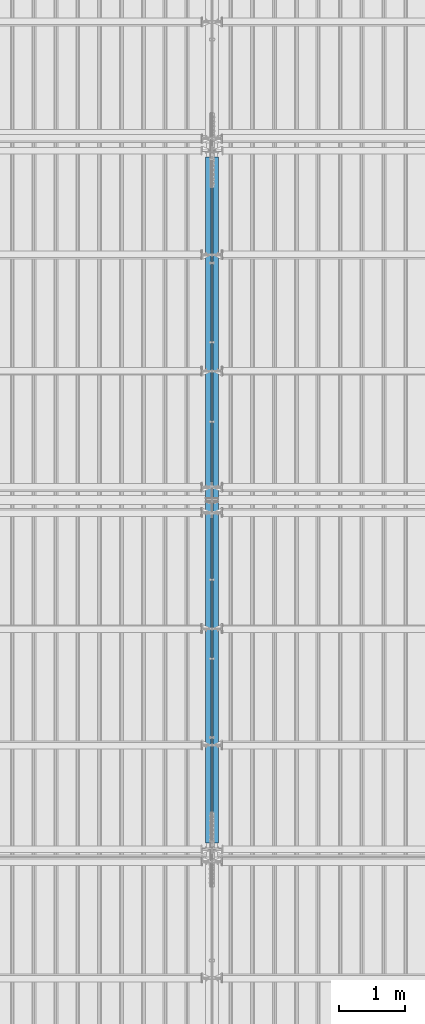
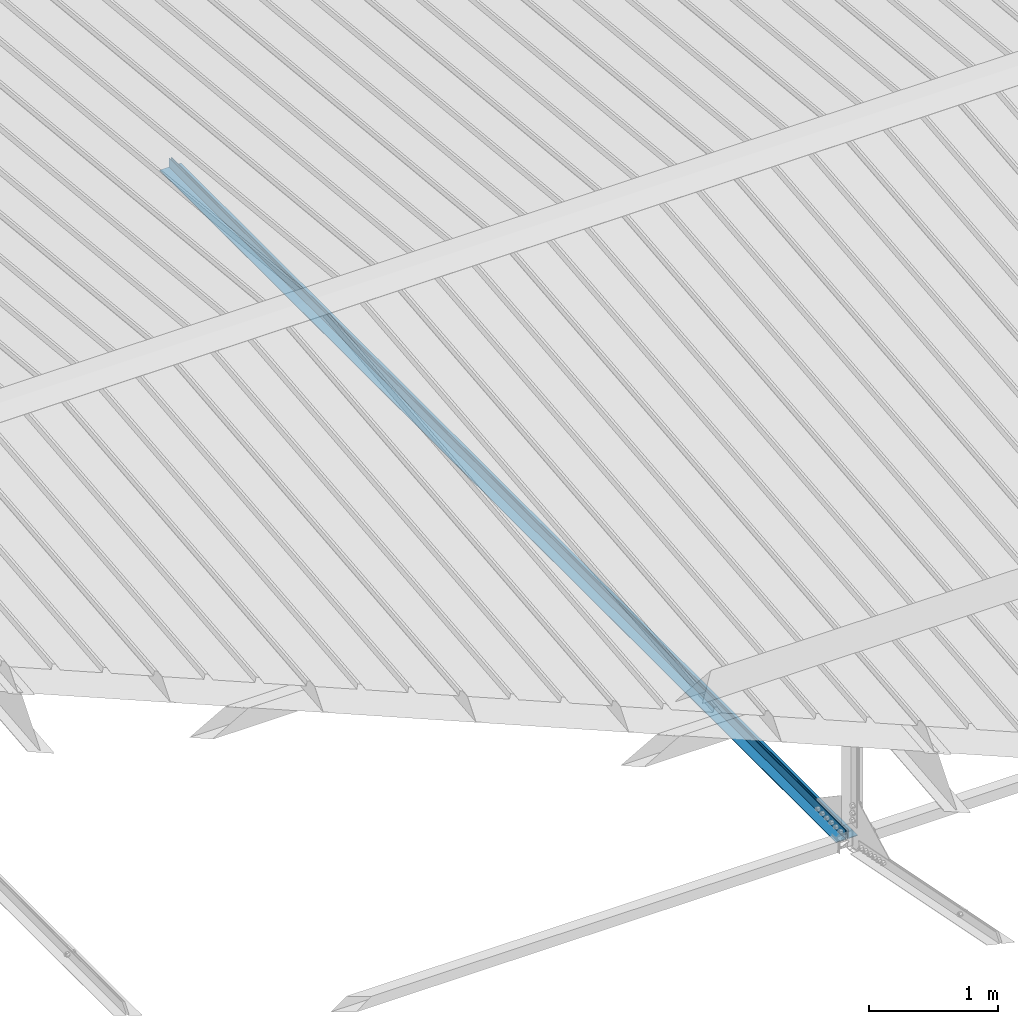
# One storey, part 276 of 709: 2 beams, 2 elements without a shape of their own.
"""IFC4 building model written with IfcOpenShell, lengths in millimetres."""

from ifc_helpers import new_model, si_unit, direction, frame, origin_with_axes, place, context, subcontext, project, spatial, polygons, material, element, aggregate, save


model = new_model("IFC4")

# Units and contexts
model_context = context("Model", 3, precision=0.2, world=origin_with_axes(), true_north=direction((0.0, 1.0)))
body_context = subcontext(model_context, "Body", "Model", "MODEL_VIEW")
ifc_project = project(units=[si_unit("LENGTHUNIT", "METRE", prefix="MILLI"), si_unit("AREAUNIT", "SQUARE_METRE"), si_unit("VOLUMEUNIT", "CUBIC_METRE"), si_unit("MASSUNIT", "GRAM", prefix="KILO"), si_unit("TIMEUNIT", "SECOND"), si_unit("PLANEANGLEUNIT", "RADIAN"), si_unit("SOLIDANGLEUNIT", "STERADIAN"), si_unit("THERMODYNAMICTEMPERATUREUNIT", "DEGREE_CELSIUS"), si_unit("LUMINOUSINTENSITYUNIT", "LUMEN")], contexts=[model_context])

# Site, building, storey
site_placement = place(None, origin_with_axes())
site = spatial("IfcSite", under=ifc_project, at=site_placement, CompositionType="ELEMENT")
building_placement = place(site_placement, origin_with_axes())
building = spatial("IfcBuilding", under=site, at=building_placement, Name="Undefined", CompositionType="ELEMENT")
storey_placement = place(building_placement, origin_with_axes())
storey = spatial("IfcBuildingStorey", under=building, at=storey_placement, Name="Undefined", CompositionType="ELEMENT", Elevation=0.0)

# Assembly, beam
assembly_1_placement = place(storey_placement, frame((33949.0, 5673.0, 6045.00002), z_axis=(0.0, 0.0, 1.0), x_axis=(0.0, 1.0, 0.0)))
assembly_1 = element("IfcElementAssembly", 1, at=assembly_1_placement, inside=storey)
ifc_material = material(Name="C345-5", Category="STEEL")
beam_1_placement = place(assembly_1_placement, origin_with_axes())
beam_1 = element("IfcBeam", 2, at=beam_1_placement, material=ifc_material, ObjectType="433", context=body_context, shape_type="Tessellation", body=[
    polygons([(100.0, -45.0, -45.0), (100.0, 45.0, -45.0), (10554.0, 45.0, -45.0), (10554.0, -45.0, -45.0), (100.0, 45.0, -39.0), (10554.0, 45.0, -39.0), (100.0, -39.0, -39.0), (10554.0, -39.0, -39.0), (100.0, -39.0, 45.0), (10554.0, -39.0, 45.0), (100.0, -45.0, 45.0), (10554.0, -45.0, 45.0)], [[[1, 2, 3, 4]], [[2, 5, 6, 3]], [[5, 7, 8, 6]], [[7, 9, 10, 8]], [[9, 11, 12, 10]], [[11, 1, 4, 12]], [[6, 8, 10, 12, 4, 3]], [[11, 9, 7, 5, 2, 1]]], closed=True),
])
aggregate(assembly_1, [beam_1])

assembly_2_placement = place(storey_placement, frame((34051.0, 16327.0, 6045.00002), z_axis=(0.0, 0.0, 1.0), x_axis=(0.0, -1.0, 0.0)))
assembly_2 = element("IfcElementAssembly", 3, at=assembly_2_placement, inside=storey)
beam_2_placement = place(assembly_2_placement, origin_with_axes())
beam_2 = element("IfcBeam", 4, at=beam_2_placement, material=ifc_material, ObjectType="434", context=body_context, shape_type="Tessellation", body=[
    polygons([(100.0, -45.0, -45.0), (100.0, 45.0, -45.0), (10554.0, 45.0, -45.0), (10554.0, -45.0, -45.0), (100.0, 45.0, -39.0), (10554.0, 45.0, -39.0), (100.0, -39.0, -39.0), (10554.0, -39.0, -39.0), (100.0, -39.0, 45.0), (10554.0, -39.0, 45.0), (100.0, -45.0, 45.0), (10554.0, -45.0, 45.0)], [[[1, 2, 3, 4]], [[2, 5, 6, 3]], [[5, 7, 8, 6]], [[7, 9, 10, 8]], [[9, 11, 12, 10]], [[11, 1, 4, 12]], [[6, 8, 10, 12, 4, 3]], [[11, 9, 7, 5, 2, 1]]], closed=True),
])
aggregate(assembly_2, [beam_2])

save(model, "model.ifc")
